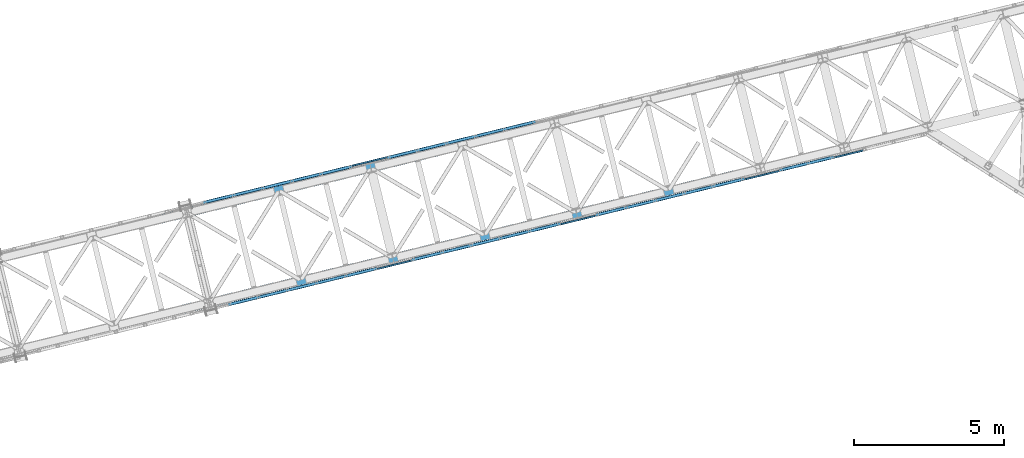
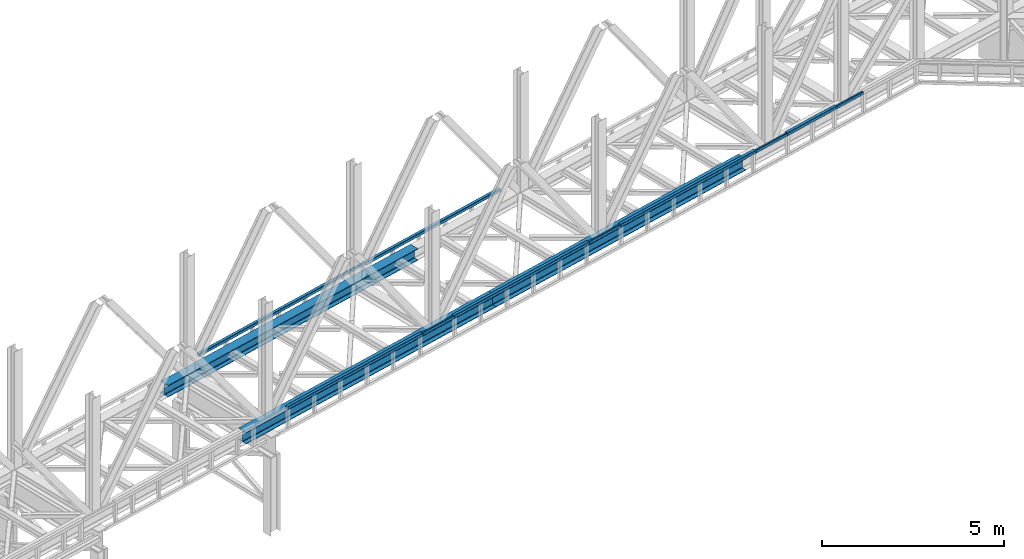
# One storey, part 18 of 92: 14 beams.
"""IFC4 building model written with IfcOpenShell, lengths in millimetres."""

from ifc_helpers import new_model, entity, si_unit, converted_unit, derived_unit, direction, frame, origin, place, context, subcontext, project, spatial, indexed_curve, outline, extrude, material, type_object, element, save


model = new_model("IFC4")

# Units and contexts
model_context = context("Model", 3, precision=0.01, world=origin(), true_north=direction((6.12303176911189e-17, 1.0)))
plan_context = context("Plan", 3, precision=0.01, world=origin(), true_north=direction((6.12303176911189e-17, 1.0)))
body_context = subcontext(model_context, "Body", "Model", "MODEL_VIEW")
ifc_project = project(units=[si_unit("LENGTHUNIT", "METRE", prefix="MILLI"), si_unit("AREAUNIT", "SQUARE_METRE"), si_unit("VOLUMEUNIT", "CUBIC_METRE"), converted_unit("PLANEANGLEUNIT", "DEGREE", entity("IfcRatioMeasure", 0.0174532925199433), si_unit("PLANEANGLEUNIT", "RADIAN"), dimensions=[0, 0, 0, 0, 0, 0, 0]), si_unit("MASSUNIT", "GRAM", prefix="KILO"), derived_unit("MASSDENSITYUNIT", [(si_unit("MASSUNIT", "GRAM", prefix="KILO"), 1), (si_unit("LENGTHUNIT", "METRE"), -3)]), derived_unit("MOMENTOFINERTIAUNIT", [(si_unit("LENGTHUNIT", "METRE"), 4)]), si_unit("TIMEUNIT", "SECOND"), si_unit("FREQUENCYUNIT", "HERTZ"), si_unit("THERMODYNAMICTEMPERATUREUNIT", "DEGREE_CELSIUS"), derived_unit("THERMALTRANSMITTANCEUNIT", [(si_unit("MASSUNIT", "GRAM", prefix="KILO"), 1), (si_unit("THERMODYNAMICTEMPERATUREUNIT", "KELVIN"), -1), (si_unit("TIMEUNIT", "SECOND"), -3)]), derived_unit("VOLUMETRICFLOWRATEUNIT", [(si_unit("LENGTHUNIT", "METRE"), 3), (si_unit("TIMEUNIT", "SECOND"), -1)]), derived_unit("MASSFLOWRATEUNIT", [(si_unit("MASSUNIT", "GRAM", prefix="KILO"), 1), (si_unit("TIMEUNIT", "SECOND"), -1)]), derived_unit("ROTATIONALFREQUENCYUNIT", [(si_unit("TIMEUNIT", "SECOND"), -1)]), si_unit("ELECTRICCURRENTUNIT", "AMPERE"), si_unit("ELECTRICVOLTAGEUNIT", "VOLT"), si_unit("POWERUNIT", "WATT"), si_unit("FORCEUNIT", "NEWTON", prefix="KILO"), si_unit("ILLUMINANCEUNIT", "LUX"), si_unit("LUMINOUSFLUXUNIT", "LUMEN"), si_unit("LUMINOUSINTENSITYUNIT", "CANDELA"), derived_unit("USERDEFINED", [(si_unit("MASSUNIT", "GRAM", prefix="KILO"), -1), (si_unit("LENGTHUNIT", "METRE"), -2), (si_unit("TIMEUNIT", "SECOND"), 3), (si_unit("LUMINOUSFLUXUNIT", "LUMEN"), 1)]), derived_unit("LINEARVELOCITYUNIT", [(si_unit("LENGTHUNIT", "METRE"), 1), (si_unit("TIMEUNIT", "SECOND"), -1)]), si_unit("PRESSUREUNIT", "PASCAL"), derived_unit("USERDEFINED", [(si_unit("LENGTHUNIT", "METRE"), -2), (si_unit("MASSUNIT", "GRAM", prefix="KILO"), 1), (si_unit("TIMEUNIT", "SECOND"), -2)]), derived_unit("LINEARFORCEUNIT", [(si_unit("MASSUNIT", "GRAM", prefix="KILO"), 1), (si_unit("LENGTHUNIT", "METRE"), 1), (si_unit("TIMEUNIT", "SECOND"), -2), (si_unit("LENGTHUNIT", "METRE"), -1)]), derived_unit("PLANARFORCEUNIT", [(si_unit("MASSUNIT", "GRAM", prefix="KILO"), 1), (si_unit("LENGTHUNIT", "METRE"), 1), (si_unit("TIMEUNIT", "SECOND"), -2), (si_unit("LENGTHUNIT", "METRE"), -2)])], contexts=[model_context, plan_context])

# Site, building, storey
site_placement = place(None, origin())
site = spatial("IfcSite", under=ifc_project, at=site_placement, CompositionType="ELEMENT")
building_placement = place(site_placement, origin())
building = spatial("IfcBuilding", under=site, at=building_placement, CompositionType="ELEMENT")
storey_placement = place(building_placement, frame((0.0, 0.0, 15900.0)))
storey = spatial("IfcBuildingStorey", under=building, at=storey_placement, Name="05", CompositionType="ELEMENT", Elevation=15900.0)

# Beams
ifc_material = material(Name="Metal painted (White)")
beam_type = type_object("IfcBeamType", PredefinedType="BEAM")
placement = place(storey_placement, origin())
element("IfcBeam", 1, at=placement, inside=storey, type_object=beam_type, material=ifc_material, ObjectType="Steel Beam", PredefinedType="BEAM", context=body_context, shape_type="SweptSolid", body=[
    extrude(outline(indexed_curve([(-195.999999999999, -150.000000000005), (-179.999999999996, -150.000000000005), (-179.999999999996, -27.7500000000041), (-178.325349715245, -19.3309644879734), (-173.556349186101, -12.1936508138996), (-166.419035512029, -7.42465028475491), (-157.999999999997, -5.75000000000425), (158.000000000005, -5.75000000000425), (166.419035512033, -7.42465028475491), (173.556349186107, -12.1936508138996), (178.325349715251, -19.3309644879734), (180.0, -27.7500000000041), (180.0, -150.000000000005), (196.000000000005, -150.000000000005), (196.000000000005, 149.999999999996), (180.0, 149.999999999996), (180.0, 27.7499999999947), (178.325349715251, 19.3309644879649), (173.556349186107, 12.1936508138912), (166.419035512033, 7.42465028474757), (158.000000000005, 5.74999999999584), (-157.999999999997, 5.74999999999373), (-166.419035512029, 7.42465028474757), (-173.556349186101, 12.1936508138912), (-178.325349715245, 19.3309644879618), (-179.999999999996, 27.7499999999968), (-179.999999999996, 149.999999999994), (-195.999999999999, 149.999999999996), (-195.999999999999, -150.000000000005)], self_intersect=False)), frame((-30278.97, 10220.76, 3489.0), z_axis=(0.971552058141469, 0.236826092990355, 0.0), x_axis=(0.0, 0.0, 1.0)), (0.0, 0.0, 1.0), 9480.00000000004),
])
element("IfcBeam", 2, at=placement, inside=storey, type_object=beam_type, material=ifc_material, ObjectType="Steel Beam", PredefinedType="BEAM", context=body_context, shape_type="SweptSolid", body=[
    extrude(outline(indexed_curve([(-195.999999999999, -150.000000000003), (-179.999999999996, -150.000000000003), (-179.999999999996, -27.750000000002), (-178.325349715245, -19.3309644879713), (-173.556349186101, -12.1936508138975), (-166.419035512029, -7.4246502847528), (-157.999999999997, -5.75000000000215), (158.000000000005, -5.75000000000215), (166.419035512033, -7.4246502847528), (173.556349186107, -12.1936508138975), (178.325349715251, -19.3309644879713), (180.0, -27.750000000002), (180.0, -150.000000000003), (196.000000000005, -150.000000000003), (196.000000000005, 149.999999999996), (180.0, 149.999999999996), (180.0, 27.7499999999947), (178.325349715251, 19.330964487967), (173.556349186107, 12.1936508138912), (166.419035512033, 7.42465028474967), (158.000000000005, 5.74999999999584), (-157.999999999997, 5.74999999999584), (-166.419035512029, 7.42465028474967), (-173.556349186101, 12.1936508138933), (-178.325349715245, 19.330964487967), (-179.999999999996, 27.7499999999999), (-179.999999999996, 149.999999999996), (-195.999999999999, 149.999999999996), (-195.999999999999, -150.000000000003)], self_intersect=False)), frame((-21068.66, 12465.87, 3489.0), z_axis=(0.971552058141469, 0.236826092990355, 0.0), x_axis=(0.0, 0.0, 1.0)), (0.0, 0.0, 1.0), 9479.99999999997),
])
element("IfcBeam", 3, at=placement, inside=storey, type_object=beam_type, material=ifc_material, ObjectType="Steel Beam", PredefinedType="BEAM", context=body_context, shape_type="SweptSolid", body=[
    extrude(outline(indexed_curve([(-195.999999999999, -150.000000000001), (-179.999999999996, -150.000000000001), (-179.999999999996, -27.7499999999999), (-178.325349715245, -19.3309644879691), (-173.556349186101, -12.1936508138954), (-166.419035512029, -7.4246502847528), (-157.999999999997, -5.75000000000005), (158.000000000005, -5.75000000000005), (166.419035512033, -7.4246502847528), (173.556349186107, -12.1936508138954), (178.325349715251, -19.3309644879691), (180.0, -27.7499999999999), (180.0, -150.000000000001), (196.000000000005, -150.000000000001), (196.000000000005, 149.999999999998), (180.0, 149.999999999998), (180.0, 27.7499999999968), (178.325349715251, 19.3309644879691), (173.556349186107, 12.1936508138933), (166.419035512033, 7.4246502847528), (158.000000000005, 5.74999999999794), (-157.999999999997, 5.74999999999584), (-166.419035512029, 7.42465028474757), (-173.556349186101, 12.1936508138933), (-178.325349715247, 19.330964487967), (-179.999999999996, 27.7499999999968), (-179.999999999996, 149.999999999996), (-195.999999999999, 149.999999999998), (-195.999999999999, -150.000000000001)], self_intersect=False)), frame((-31013.13, 13232.57, 3489.0), z_axis=(0.971552058141469, 0.236826092990355, 0.0), x_axis=(0.0, 0.0, 1.0)), (0.0, 0.0, 1.0), 9480.00000000004),
])
element("IfcBeam", 4, at=placement, inside=storey, type_object=beam_type, material=ifc_material, ObjectType="Steel Beam", PredefinedType="BEAM", context=body_context, shape_type="SweptSolid", body=[
    extrude(outline(indexed_curve([(29.4768951153319, -56.8428769008003), (33.3787015556544, -56.8428769008003), (36.9835006656888, -55.3497202197897), (39.7424944585191, -52.5907264269642), (41.2356511395258, -48.9859273169303), (56.8428769008051, 29.4768951153294), (56.8428769008049, 33.3787015556509), (55.3497202197946, 36.9835006656864), (52.5907264269671, 39.7424944585227), (48.9859273169311, 41.2356511395243), (-29.476895115329, 56.8428769008041), (-33.3787015556507, 56.8428769008084), (-36.9835006656858, 55.3497202197935), (-39.742494458517, 52.5907264269638), (-41.2356511395237, 48.9859273169299), (-56.8428769008031, -29.4768951153298), (-56.8428769008019, -33.3787015556515), (-55.3497202197906, -36.9835006656828), (-52.5907264269633, -39.7424944585146), (-48.9859273169282, -41.2356511395205), (29.4768951153319, -56.8428769008003)], self_intersect=False), holes=[indexed_curve([(-50.9634988887046, -25.5484203233951), (-37.3071763475817, 43.1065493048336), (-35.8140196665771, 46.7113484148679), (-33.0550258737489, 49.4703422076983), (-29.4502267637103, 50.9634988887036), (-25.5484203233909, 50.9634988887042), (43.1065493048361, 37.3071763475801), (46.7113484148721, 35.8140196665785), (49.4703422077023, 33.0550258737505), (50.9634988887086, 29.4502267637158), (50.9634988887087, 25.5484203233943), (37.3071763475889, -43.1065493048351), (35.8140196665843, -46.7113484148694), (33.055025873758, -49.4703422076957), (29.4502267637217, -50.9634988887059), (25.5484203233971, -50.9634988887055), (-43.1065493048287, -37.307176347586), (-46.7113484148688, -35.8140196665836), (-49.4703422076953, -33.0550258737475), (-50.9634988887024, -29.450226763717), (-50.9634988887046, -25.5484203233951)], self_intersect=False)]), frame((-23487.25, 15272.94, 3830.0), z_axis=(0.971552058141621, 0.236826092989728, 0.0), x_axis=(0.232275546019843, -0.952883957770766, -0.195090322015997)), (0.0, 0.0, 1.0), 5120.00000000002),
])
element("IfcBeam", 5, at=placement, inside=storey, type_object=beam_type, material=ifc_material, ObjectType="Steel Beam", PredefinedType="BEAM", context=body_context, shape_type="SweptSolid", body=[
    extrude(outline(indexed_curve([(29.4768951153935, -56.8428769007593), (33.3787015557151, -56.8428769007593), (36.983500665747, -55.349720219749), (39.742494458576, -52.590726426912), (41.2356511395787, -48.9859273168765), (56.8428769007747, 29.4768951153998), (56.8428769007672, 33.378701555722), (55.3497202197551, 36.983500665751), (52.5907264269217, 39.7424944585804), (48.985927316885, 41.2356511395824), (-29.4768951153901, 56.8428769007763), (-33.3787015557126, 56.842876900772), (-36.9835006657444, 55.3497202197617), (-39.7424944585747, 52.5907264269294), (-41.2356511395753, 48.9859273168935), (-56.8428769007713, -29.4768951153829), (-56.8428769007638, -33.378701555705), (-55.3497202197535, -36.9835006657425), (-52.5907264269192, -39.7424944585677), (-48.9859273168817, -41.2356511395654), (29.4768951153935, -56.8428769007593)], self_intersect=False), holes=[indexed_curve([(-50.9634988886751, -25.5484203234422), (-37.307176347631, 43.1065493048023), (-35.8140196666262, 46.7113484148374), (-33.055025873804, 49.4703422076669), (-29.4502267637722, 50.9634988886772), (-25.5484203234488, 50.9634988886857), (43.106549304796, 37.3071763476402), (46.7113484148319, 35.8140196666341), (49.470342207663, 33.0550258738095), (50.9634988886761, 29.4502267637803), (50.9634988886805, 25.5484203234587), (37.3071763476375, -43.1065493047859), (35.8140196666368, -46.7113484148218), (33.0550258738057, -49.4703422076584), (29.4502267637718, -50.9634988886683), (25.5484203234514, -50.963498888673), (-43.1065493047935, -37.3071763476275), (-46.7113484148302, -35.8140196666256), (-49.4703422076655, -33.0550258738002), (-50.9634988886707, -29.4502267637637), (-50.9634988886751, -25.5484203234422)], self_intersect=False)]), frame((-29627.46, 13776.2, 3830.0), z_axis=(0.971552058141621, 0.236826092989728, 0.0), x_axis=(0.232275546019893, -0.952883957770972, -0.19509032201493)), (0.0, 0.0, 1.0), 5119.99999999998),
])
element("IfcBeam", 6, at=placement, inside=storey, type_object=beam_type, material=ifc_material, ObjectType="Steel Beam", PredefinedType="BEAM", context=body_context, shape_type="SweptSolid", body=[
    extrude(outline(indexed_curve([(9.86118950714156, -52.9410704605108), (13.7629959474637, -52.9410704605108), (17.3677950575018, -51.4479137795173), (20.1267888503371, -48.688919986689), (21.619945531354, -45.0841208766589), (37.2271712928117, 33.3787015555653), (37.2271712928194, 37.280507995887), (35.7340146118204, 40.8853071059253), (32.9750208189955, 43.6443008987598), (29.3702217089667, 45.1374575797777), (-9.8611895071486, 52.9410704605078), (-13.7629959474699, 52.941070460512), (-17.3677950575068, 51.4479137795139), (-20.1267888503412, 48.6889199866898), (-21.6199455313581, 45.0841208766597), (-37.2271712928179, -33.3787015555641), (-37.2271712928236, -37.2805079958862), (-35.7340146118264, -40.8853071059285), (-32.9750208190027, -43.6443008987584), (-29.3702217089748, -45.1374575797806), (9.86118950714156, -52.9410704605108)], self_intersect=False), holes=[indexed_curve([(-31.3477932807115, -29.4502267636426), (-17.6914707394336, 39.2047428645554), (-16.1983140584188, 42.8095419745858), (-13.4393202655864, 45.5685357674103), (-9.83452115554951, 47.0616924484085), (-5.93271471522702, 47.0616924483995), (23.4908436968574, 41.2089827878524), (27.0956428068891, 39.7158261068383), (29.854636599712, 36.9568323140043), (31.3477932807151, 33.3520332039651), (31.3477932807074, 29.4502267636434), (17.6914707394295, -39.2047428645545), (16.1983140584126, -42.8095419745846), (13.4393202655773, -45.5685357674129), (9.83452115554126, -47.0616924484068), (5.93271471521876, -47.0616924483979), (-23.4908436968687, -41.2089827878502), (-27.0956428068983, -39.7158261068365), (-29.85463659972, -36.9568323140071), (-31.3477932807192, -33.3520332039643), (-31.3477932807115, -29.4502267636426)], self_intersect=False)]), frame((-24657.58, 15007.08, 3830.0), z_axis=(0.97155205814156, 0.236826092989979, 0.0), x_axis=(-0.232275546019865, 0.952883957770302, 0.195090322018236)), (0.0, 0.0, 1.0), 1200.00000000001),
])
element("IfcBeam", 7, at=placement, inside=storey, type_object=beam_type, material=ifc_material, ObjectType="Steel Beam", PredefinedType="BEAM", context=body_context, shape_type="SweptSolid", body=[
    extrude(outline(indexed_curve([(29.4768951153359, -56.8428769008), (33.3787015556589, -56.8428769008), (36.9835006656937, -55.3497202197894), (39.7424944585219, -52.5907264269634), (41.2356511395285, -48.9859273169295), (56.8428769008057, 29.4768951153306), (56.8428769008063, 33.3787015556564), (55.3497202197999, 36.9835006656911), (52.5907264269695, 39.7424944585234), (48.9859273169335, 41.235651139525), (-29.4768951153284, 56.8428769008029), (-33.3787015556505, 56.8428769008072), (-36.9835006656853, 55.3497202197966), (-39.7424944585123, 52.5907264269659), (-41.2356511395197, 48.9859273169278), (-56.842876900797, -29.4768951153324), (-56.8428769007967, -33.3787015556539), (-55.3497202197895, -36.9835006656843), (-52.590726426959, -39.7424944585167), (-48.9859273169239, -41.2356511395224), (29.4768951153359, -56.8428769008)], self_intersect=False), holes=[indexed_curve([(-50.9634988886993, -25.548420323393), (-37.3071763475822, 43.1065493048325), (-35.8140196665777, 46.7113484148669), (-33.0550258737465, 49.4703422076967), (-29.4502267637117, 50.9634988887073), (-25.5484203233887, 50.9634988887073), (43.1065493048367, 37.3071763475898), (46.7113484148703, 35.8140196665843), (49.4703422077049, 33.0550258737511), (50.9634988887112, 29.4502267637165), (50.9634988887089, 25.5484203233955), (37.3071763475943, -43.1065493048305), (35.8140196665864, -46.7113484148686), (33.0550258737603, -49.470342207695), (29.4502267637234, -50.9634988887052), (25.5484203234004, -50.9634988887052), (-43.1065493048271, -37.3071763475873), (-46.7113484148636, -35.8140196665857), (-49.4703422076906, -33.0550258737496), (-50.9634988886999, -29.4502267637187), (-50.9634988886993, -25.548420323393)], self_intersect=False)]), frame((-10375.81, 14857.24, 3830.0), z_axis=(0.971552058141501, 0.236826092990222, 0.0), x_axis=(0.232275546020368, -0.952883957770643, -0.195090322015972)), (0.0, 0.0, 1.0), 1879.99999999999),
])
element("IfcBeam", 8, at=placement, inside=storey, type_object=beam_type, material=ifc_material, ObjectType="Steel Beam", PredefinedType="BEAM", context=body_context, shape_type="SweptSolid", body=[
    extrude(outline(indexed_curve([(29.4768951153333, -56.8428769007995), (33.3787015556563, -56.8428769007995), (36.9835006656911, -55.3497202197889), (39.7424944585193, -52.5907264269629), (41.2356511395264, -48.9859273169291), (56.8428769008031, 29.4768951153312), (56.8428769008029, 33.3787015556527), (55.349720219795, 36.9835006656876), (52.5907264269674, 39.7424944585238), (48.9859273169314, 41.2356511395254), (-29.4768951153304, 56.8428769008034), (-33.3787015556505, 56.8428769008072), (-36.9835006656882, 55.3497202197927), (-39.7424944585173, 52.5907264269625), (-41.2356511395223, 48.9859273169283), (-56.8428769008011, -29.4768951153316), (-56.8428769007987, -33.3787015556535), (-55.3497202197916, -36.9835006656839), (-52.5907264269611, -39.7424944585163), (-48.985927316928, -41.2356511395216), (29.4768951153333, -56.8428769007995)], self_intersect=False), holes=[indexed_curve([(-50.9634988887069, -25.5484203233959), (-37.3071763475868, 43.1065493048334), (-35.8140196665818, 46.7113484148677), (-33.0550258737507, 49.4703422076975), (-29.4502267637167, 50.9634988887039), (-25.5484203233958, 50.9634988887043), (43.1065493048318, 37.3071763475864), (46.7113484148694, 35.8140196665801), (49.4703422076982, 33.0550258737525), (50.9634988887045, 29.4502267637178), (50.9634988887069, 25.5484203233959), (37.3071763475868, -43.1065493048334), (35.8140196665843, -46.7113484148682), (33.0550258737561, -49.4703422076942), (29.4502267637167, -50.9634988887039), (25.5484203233958, -50.9634988887043), (-43.1065493048338, -37.307176347586), (-46.7113484148698, -35.8140196665844), (-49.4703422076973, -33.0550258737482), (-50.9634988887045, -29.4502267637178), (-50.9634988887069, -25.5484203233959)], self_intersect=False)]), frame((-16516.02, 13360.5, 3830.0), z_axis=(0.971552058141501, 0.236826092990222, 0.0), x_axis=(0.232275546020368, -0.952883957770643, -0.195090322015972)), (0.0, 0.0, 1.0), 5119.99999999996),
])
element("IfcBeam", 9, at=placement, inside=storey, type_object=beam_type, material=ifc_material, ObjectType="Steel Beam", PredefinedType="BEAM", context=body_context, shape_type="SweptSolid", body=[
    extrude(outline(indexed_curve([(29.476895115334, -56.8428769008007), (33.3787015556565, -56.8428769008007), (36.9835006656908, -55.3497202197901), (39.7424944585191, -52.5907264269642), (41.2356511395258, -48.9859273169303), (56.8428769008051, 29.4768951153294), (56.8428769008049, 33.3787015556509), (55.3497202197966, 36.983500665686), (52.5907264269691, 39.7424944585223), (48.9859273169332, 41.2356511395239), (-29.476895115329, 56.8428769008041), (-33.3787015556486, 56.842876900808), (-36.9835006656858, 55.3497202197935), (-39.742494458515, 52.5907264269634), (-41.2356511395216, 48.9859273169295), (-56.8428769008, -29.4768951153304), (-56.8428769007998, -33.3787015556519), (-55.3497202197906, -36.9835006656828), (-52.5907264269612, -39.742494458515), (-48.9859273169282, -41.2356511395205), (29.476895115334, -56.8428769008007)], self_intersect=False), holes=[indexed_curve([(-50.9634988887025, -25.5484203233955), (-37.3071763475817, 43.1065493048336), (-35.814019666575, 46.7113484148675), (-33.0550258737469, 49.4703422076979), (-29.4502267637134, 50.9634988887043), (-25.5484203233909, 50.9634988887042), (43.106549304837, 37.3071763475844), (46.7113484148721, 35.8140196665785), (49.4703422077054, 33.0550258737499), (50.9634988887086, 29.4502267637158), (50.9634988887087, 25.5484203233943), (37.3071763475909, -43.1065493048355), (35.8140196665843, -46.7113484148694), (33.055025873758, -49.4703422076957), (29.4502267637196, -50.9634988887055), (25.5484203233971, -50.9634988887055), (-43.1065493048308, -37.3071763475856), (-46.7113484148637, -35.8140196665846), (-49.4703422076953, -33.0550258737475), (-50.9634988887024, -29.450226763717), (-50.9634988887025, -25.5484203233955)], self_intersect=False)]), frame((-22656.23, 11863.76, 3830.0), z_axis=(0.971552058141621, 0.236826092989728, 0.0), x_axis=(0.232275546019843, -0.952883957770766, -0.195090322015997)), (0.0, 0.0, 1.0), 5120.00000000002),
])
element("IfcBeam", 10, at=placement, inside=storey, type_object=beam_type, material=ifc_material, ObjectType="Steel Beam", PredefinedType="BEAM", context=body_context, shape_type="SweptSolid", body=[
    extrude(outline(indexed_curve([(29.4768951153935, -56.8428769007593), (33.3787015557151, -56.8428769007593), (36.983500665747, -55.349720219749), (39.742494458576, -52.590726426912), (41.2356511395787, -48.9859273168765), (56.8428769007726, 29.4768951154003), (56.8428769007651, 33.3787015557224), (55.349720219756, 36.9835006657552), (52.5907264269217, 39.7424944585804), (48.985927316885, 41.2356511395824), (-29.4768951153921, 56.8428769007767), (-33.3787015557126, 56.842876900772), (-36.9835006657473, 55.3497202197579), (-39.7424944585747, 52.5907264269294), (-41.2356511395753, 48.9859273168935), (-56.8428769007713, -29.4768951153829), (-56.8428769007638, -33.378701555705), (-55.3497202197555, -36.9835006657421), (-52.5907264269192, -39.7424944585677), (-48.9859273168837, -41.235651139565), (29.4768951153935, -56.8428769007593)], self_intersect=False), holes=[indexed_curve([(-50.9634988886772, -25.5484203234418), (-37.3071763476341, 43.1065493048029), (-35.8140196666262, 46.7113484148374), (-33.055025873804, 49.4703422076669), (-29.4502267637742, 50.9634988886776), (-25.5484203234488, 50.9634988886857), (43.1065493047939, 37.3071763476406), (46.7113484148319, 35.8140196666341), (49.470342207663, 33.0550258738095), (50.9634988886741, 29.4502267637807), (50.9634988886785, 25.5484203234592), (37.3071763476354, -43.1065493047855), (35.8140196666368, -46.7113484148218), (33.0550258738037, -49.470342207658), (29.4502267637718, -50.9634988886683), (25.5484203234493, -50.9634988886726), (-43.1065493047955, -37.3071763476271), (-46.7113484148281, -35.814019666626), (-49.4703422076655, -33.0550258738002), (-50.9634988886727, -29.4502267637633), (-50.9634988886772, -25.5484203234418)], self_intersect=False)]), frame((-28796.44, 10367.02, 3830.0), z_axis=(0.971552058141621, 0.236826092989728, 0.0), x_axis=(0.232275546019893, -0.952883957770972, -0.19509032201493)), (0.0, 0.0, 1.0), 5119.99999999998),
])
element("IfcBeam", 11, at=placement, inside=storey, type_object=beam_type, material=ifc_material, ObjectType="Steel Beam", PredefinedType="BEAM", context=body_context, shape_type="SweptSolid", body=[
    extrude(outline(indexed_curve([(9.86118950714821, -52.94107046051), (13.7629959474724, -52.94107046051), (17.3677950575093, -51.4479137795159), (20.1267888503473, -48.6889199866879), (21.6199455313597, -45.0841208766568), (37.2271712928107, 33.3787015555687), (37.2271712928189, 37.2805079958903), (35.7340146118184, 40.8853071059286), (32.9750208189941, 43.6443008987626), (29.3702217089642, 45.1374575797804), (-9.86118950714905, 52.9410704605057), (-13.7629959474724, 52.94107046051), (-17.3677950575101, 51.4479137795116), (-20.1267888503473, 48.6889199866879), (-21.6199455313597, 45.0841208766568), (-37.2271712928107, -33.3787015555687), (-37.2271712928189, -37.2805079958903), (-35.7340146118193, -40.8853071059329), (-32.9750208189941, -43.6443008987626), (-29.370221708965, -45.1374575797846), (9.86118950714821, -52.94107046051)], self_intersect=False), holes=[indexed_curve([(-31.3477932807058, -29.4502267636464), (-17.6914707394375, 39.2047428645534), (-16.19831405842, 42.8095419745835), (-13.439320265588, 45.5685357674083), (-9.83452115555026, 47.0616924484066), (-5.93271471522776, 47.0616924483981), (23.4908436968584, 41.2089827878538), (27.0956428068872, 39.7158261068407), (29.8546365997115, 36.9568323140067), (31.347793280712, 33.3520332039684), (31.3477932807058, 29.4502267636464), (17.6914707394355, -39.204742864553), (16.19831405842, -42.8095419745835), (13.439320265583, -45.5685357674117), (9.83452115555026, -47.0616924484066), (5.9327147152257, -47.0616924483977), (-23.4908436968605, -41.2089827878534), (-27.0956428068872, -39.7158261068407), (-29.8546365997103, -36.9568323140114), (-31.3477932807141, -33.3520332039679), (-31.3477932807058, -29.4502267636464)], self_intersect=False)]), frame((-23817.62, 11561.23, 3830.0), z_axis=(0.971552058141752, 0.236826092989194, 0.0), x_axis=(-0.232275546019742, 0.952883957770353, 0.195090322018133)), (0.0, 0.0, 1.0), 1200.00000000001),
])
element("IfcBeam", 12, at=placement, inside=storey, type_object=beam_type, material=ifc_material, ObjectType="Steel Beam", PredefinedType="BEAM", context=body_context, shape_type="SweptSolid", body=[
    extrude(outline(indexed_curve([(9.86118950714672, -52.9410704605091), (13.7629959474714, -52.9410704605091), (17.3677950575073, -51.4479137795148), (20.1267888503442, -48.6889199866865), (21.6199455313602, -45.0841208766561), (37.2271712928074, 33.3787015555702), (37.2271712928146, 37.2805079958919), (35.7340146118146, 40.8853071059301), (32.9750208189909, 43.6443008987639), (29.3702217089594, 45.1374575797819), (-9.86118950715376, 52.9410704605061), (-13.7629959474776, 52.9410704605104), (-17.3677950575143, 51.4479137795117), (-20.1267888503509, 48.6889199866878), (-21.6199455313643, 45.084120876657), (-37.2271712928121, -33.3787015555693), (-37.2271712928208, -37.2805079958907), (-35.7340146118201, -40.8853071059335), (-32.9750208189955, -43.644300898763), (-29.3702217089643, -45.1374575797853), (9.86118950714672, -52.9410704605091)], self_intersect=False), holes=[indexed_curve([(-31.3477932807062, -29.450226763647), (-17.6914707394376, 39.2047428645528), (-16.1983140584241, 42.8095419745837), (-13.4393202655922, 45.5685357674085), (-9.8345211555534, 47.0616924484067), (-5.93271471523247, 47.0616924483986), (23.4908436968547, 41.208982787855), (27.095642806887, 39.7158261068413), (29.8546365997067, 36.9568323140083), (31.3477932807108, 33.3520332039692), (31.3477932807036, 29.4502267636475), (17.6914707394355, -39.2047428645524), (16.1983140584195, -42.8095419745827), (13.4393202655846, -45.5685357674114), (9.83452115554877, -47.0616924484058), (5.93271471522577, -47.0616924483973), (-23.4908436968593, -41.2089827878541), (-27.0956428068896, -39.7158261068408), (-29.8546365997121, -36.9568323140116), (-31.3477932807129, -33.3520332039688), (-31.3477932807062, -29.450226763647)], self_intersect=False)]), frame((-17677.15, 13056.88, 3830.0), z_axis=(0.971552058141436, 0.236826092990489, 0.0), x_axis=(-0.232275546020267, 0.95288395777023, 0.195090322018108)), (0.0, 0.0, 1.0), 1200.00000000001),
])
element("IfcBeam", 13, at=placement, inside=storey, type_object=beam_type, material=ifc_material, ObjectType="Steel Beam", PredefinedType="BEAM", context=body_context, shape_type="SweptSolid", body=[
    extrude(outline(indexed_curve([(9.86118950714672, -52.9410704605091), (13.7629959474714, -52.9410704605091), (17.3677950575073, -51.4479137795148), (20.1267888503442, -48.6889199866865), (21.6199455313602, -45.0841208766561), (37.2271712928074, 33.3787015555702), (37.2271712928146, 37.2805079958919), (35.7340146118146, 40.8853071059301), (32.9750208189909, 43.6443008987639), (29.3702217089594, 45.1374575797819), (-9.86118950715376, 52.9410704605061), (-13.7629959474776, 52.9410704605104), (-17.3677950575143, 51.4479137795117), (-20.1267888503509, 48.6889199866878), (-21.6199455313643, 45.084120876657), (-37.2271712928121, -33.3787015555693), (-37.2271712928208, -37.2805079958907), (-35.7340146118201, -40.8853071059335), (-32.9750208189955, -43.644300898763), (-29.3702217089643, -45.1374575797853), (9.86118950714672, -52.9410704605091)], self_intersect=False), holes=[indexed_curve([(-31.3477932807062, -29.450226763647), (-17.6914707394376, 39.2047428645528), (-16.1983140584241, 42.8095419745837), (-13.4393202655922, 45.5685357674085), (-9.8345211555534, 47.0616924484067), (-5.93271471523247, 47.0616924483986), (23.4908436968547, 41.208982787855), (27.095642806887, 39.7158261068413), (29.8546365997067, 36.9568323140083), (31.3477932807108, 33.3520332039692), (31.3477932807036, 29.4502267636475), (17.6914707394355, -39.2047428645524), (16.1983140584195, -42.8095419745827), (13.4393202655846, -45.5685357674114), (9.83452115554877, -47.0616924484058), (5.93271471522577, -47.0616924483973), (-23.4908436968593, -41.2089827878541), (-27.0956428068896, -39.7158261068408), (-29.8546365997121, -36.9568323140116), (-31.3477932807129, -33.3520332039688), (-31.3477932807062, -29.450226763647)], self_intersect=False)]), frame((-11536.94, 14553.62, 3830.0), z_axis=(0.971552058141436, 0.236826092990489, 0.0), x_axis=(-0.232275546020267, 0.95288395777023, 0.195090322018108)), (0.0, 0.0, 1.0), 1200.00000000001),
])
element("IfcBeam", 14, at=placement, inside=storey, type_object=beam_type, material=ifc_material, ObjectType="Steel Beam", PredefinedType="BEAM", context=body_context, shape_type="SweptSolid", body=[
    extrude(outline(indexed_curve([(9.86118950714643, -52.9410704605091), (13.7629959474711, -52.9410704605091), (17.3677950575072, -51.4479137795148), (20.1267888503449, -48.6889199866867), (21.6199455313591, -45.0841208766559), (37.2271712928088, 33.3787015555699), (37.2271712928163, 37.2805079958916), (35.7340146118152, 40.88530710593), (32.9750208189917, 43.6443008987638), (29.3702217089602, 45.1374575797817), (-9.86118950715165, 52.9410704605057), (-13.7629959474755, 52.94107046051), (-17.3677950575124, 51.4479137795114), (-20.1267888503493, 48.6889199866875), (-21.6199455313635, 45.0841208766568), (-37.2271712928132, -33.3787015555691), (-37.2271712928186, -37.2805079958911), (-35.7340146118204, -40.8853071059334), (-32.9750208189961, -43.6443008987629), (-29.3702217089634, -45.1374575797855), (9.86118950714643, -52.9410704605091)], self_intersect=False), holes=[indexed_curve([(-31.3477932807045, -29.4502267636474), (-17.6914707394377, 39.2047428645528), (-16.1983140584235, 42.8095419745835), (-13.4393202655911, 45.5685357674083), (-9.83452115555179, 47.0616924484064), (-5.93271471523111, 47.0616924483984), (23.490843696855, 41.2089827878549), (27.0956428068874, 39.7158261068412), (29.8546365997086, 36.9568323140079), (31.347793280712, 33.352033203969), (31.3477932807045, 29.4502267636474), (17.6914707394375, -39.2047428645528), (16.1983140584212, -42.8095419745831), (13.4393202655858, -45.5685357674117), (9.83452115554973, -47.061692448406), (5.93271471522673, -47.0616924483975), (-23.4908436968574, -41.2089827878545), (-27.0956428068897, -39.7158261068407), (-29.8546365997117, -36.9568323140117), (-31.347793280712, -33.352033203969), (-31.3477932807045, -29.4502267636474)], self_intersect=False)]), frame((-8544.56, 15283.05, 3830.0), z_axis=(0.971552058141469, 0.236826092990356, 0.0), x_axis=(-0.232275546020267, 0.95288395777023, 0.195090322018108)), (0.0, 0.0, 1.0), 999.999999999982),
])

save(model, "model.ifc")
